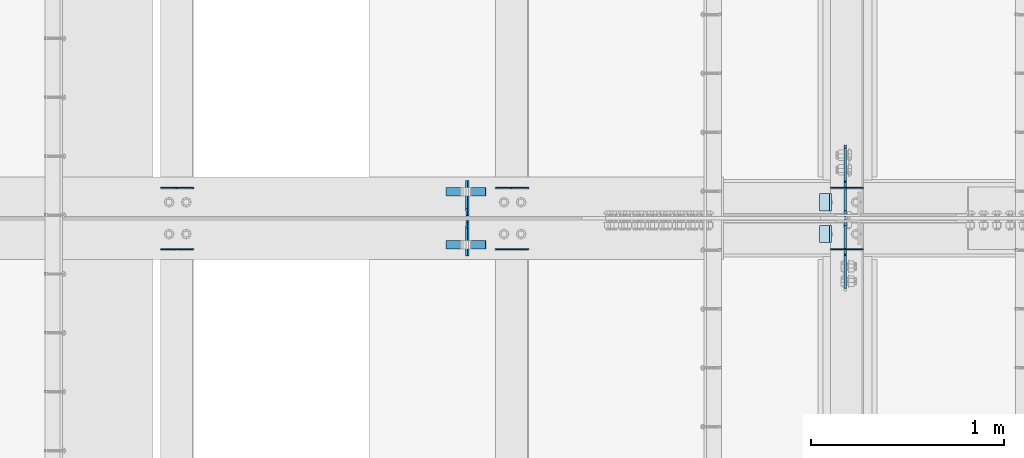
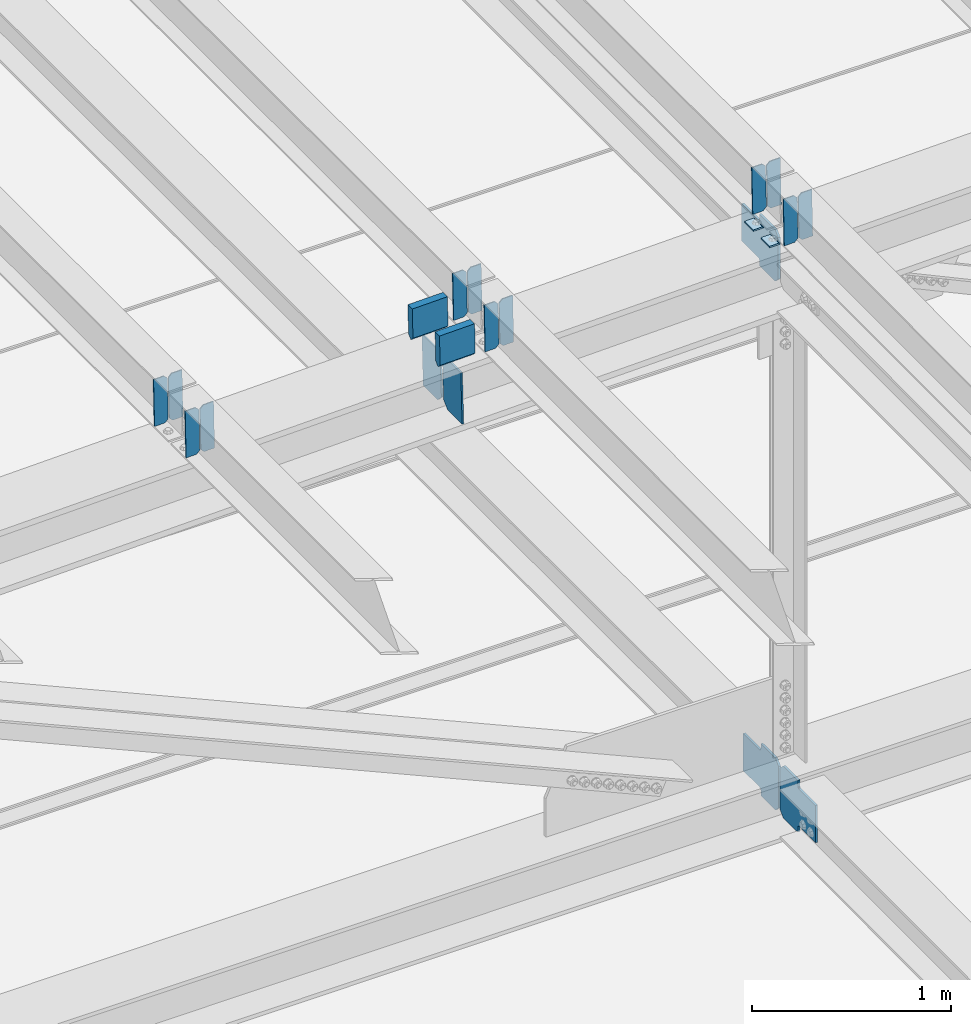
# One storey, part 3292 of 3843: 21 plates, 8 elements without a shape of their own.
"""IFC2X3 building model written with IfcOpenShell, lengths in millimetres."""

from ifc_helpers import new_model, si_unit, frame, origin_with_axes, place, context, subcontext, project, spatial, faceted_brep, material, type_object, element, aggregate, save


model = new_model("IFC2X3")

# Units and contexts
model_context = context("Model", 3, precision=1e-05, world=origin_with_axes())
body_context = subcontext(model_context, "Body", "Model", "MODEL_VIEW")
ifc_project = project(units=[si_unit("LENGTHUNIT", "METRE", prefix="MILLI"), si_unit("AREAUNIT", "SQUARE_METRE"), si_unit("VOLUMEUNIT", "CUBIC_METRE"), si_unit("MASSUNIT", "GRAM", prefix="KILO"), si_unit("TIMEUNIT", "SECOND"), si_unit("PLANEANGLEUNIT", "RADIAN"), si_unit("SOLIDANGLEUNIT", "STERADIAN"), si_unit("THERMODYNAMICTEMPERATUREUNIT", "DEGREE_CELSIUS"), si_unit("LUMINOUSINTENSITYUNIT", "LUMEN")], contexts=[model_context])

# Site, building, storey
site_placement = place(None, origin_with_axes())
site = spatial("IfcSite", under=ifc_project, at=site_placement, CompositionType="ELEMENT")
building_placement = place(site_placement, origin_with_axes())
building = spatial("IfcBuilding", under=site, at=building_placement, Name="Undefined", CompositionType="ELEMENT")
storey_placement = place(building_placement, origin_with_axes())
storey = spatial("IfcBuildingStorey", under=building, at=storey_placement, Name="Undefined", CompositionType="ELEMENT", Elevation=0.0)

# Assembly, plates
assembly_1_placement = place(storey_placement, origin_with_axes())
assembly_1 = element("IfcElementAssembly", 1, at=assembly_1_placement, inside=storey, Name="BEAM", AssemblyPlace="NOTDEFINED", PredefinedType="RIGID_FRAME")
ifc_material = material(Name="STEEL/A572-50")
plate_type_1 = type_object("IfcPlateType", PredefinedType="NOTDEFINED")
plate_1_placement = place(assembly_1_placement, frame((49078.8964783429, 42358.0054631626, 45746.0795155229), z_axis=(-0.0211520980083369, -0.00110850299980666, 0.999775654820093), x_axis=(-0.999776269348562, 2.42819999967805e-05, -0.0211520840074087)))
plate_1 = element("IfcPlate", 2, at=plate_1_placement, type_object=plate_type_1, material=ifc_material, Name="PLATE", context=body_context, shape_type="Brep", body=[
    faceted_brep([(0.0, -3.17499999999927, 0.0), (6.83940015733242e-10, -3.17499999996653, 288.924999998613), (6.54836185276508e-10, 3.17500000001746, 288.924999998591), (0.0, 3.17499999999927, 0.0), (60.3250007643655, -3.17500000017753, 288.924999998606), (60.3250007643219, 3.17499999979918, 288.924999998584), (79.3750000013097, -3.17500000025029, 269.875000761494), (79.375000001266, 3.17499999972642, 269.875000761487), (79.375000000713, -3.17500000026484, 19.0499992370605), (79.3750000006985, 3.17499999971187, 19.0499992370533), (60.325000763667, -3.17500000020664, -1.45519152283669e-11), (60.3250007636234, 3.17499999977736, -3.63797880709171e-11)], [[[0, 1, 2, 3]], [[1, 4, 5, 2]], [[4, 6, 7, 5]], [[6, 8, 9, 7]], [[8, 10, 11, 9]], [[10, 0, 3, 11]], [[5, 7, 9, 11, 3, 2]], [[10, 8, 6, 4, 1, 0]]]),
])
plate_2_placement = place(assembly_1_placement, frame((48993.1906576532, 42358.0074736207, 45744.266253037), z_axis=(-0.0211520980083369, -0.00110850299980666, 0.999775654820093), x_axis=(-0.999776269348562, 2.42819999967805e-05, -0.0211520840074087)))
plate_2 = element("IfcPlate", 3, at=plate_2_placement, type_object=plate_type_1, material=ifc_material, Name="PLATE", context=body_context, shape_type="Brep", body=[
    faceted_brep([(4.36557456851006e-11, -3.17499999998836, 19.0499992370969), (6.11180439591408e-10, -3.17499999996653, 269.875000761516), (5.96628524363041e-10, 3.17500000001746, 269.875000761502), (1.45519152283669e-11, 3.17499999998836, 19.0499992370824), (19.0499992376572, -3.17500000003201, 288.924999998606), (19.0499992376281, 3.1749999999447, 288.924999998584), (79.3750000013242, -3.17500000025029, 288.924999998591), (79.3750000013097, 3.1749999997337, 288.92499999857), (79.3750000006548, -3.17500000026484, -2.18278728425503e-11), (79.3750000006403, 3.17499999969732, -2.91038304567337e-11), (19.0499992370023, -3.17500000005384, 0.0), (19.0499992369587, 3.17499999992287, -1.45519152283669e-11)], [[[0, 1, 2, 3]], [[1, 4, 5, 2]], [[4, 6, 7, 5]], [[6, 8, 9, 7]], [[8, 10, 11, 9]], [[10, 0, 3, 11]], [[5, 7, 9, 11, 3, 2]], [[10, 8, 6, 4, 1, 0]]]),
])

assembly_2_placement = place(storey_placement, origin_with_axes())
assembly_2 = element("IfcElementAssembly", 4, at=assembly_2_placement, inside=storey, Name="BEAM", AssemblyPlace="NOTDEFINED", PredefinedType="RIGID_FRAME")
plate_3_placement = place(assembly_2_placement, frame((49078.8964783465, 42041.8179140765, 45745.0264253251), z_axis=(-0.0211520981022549, -0.00549162299942689, 0.999761186895503), x_axis=(-0.999776269345233, 0.000116185000071389, -0.0211517790072879)))
plate_3 = element("IfcPlate", 5, at=plate_3_placement, type_object=plate_type_1, material=ifc_material, Name="PLATE", context=body_context, shape_type="Brep", body=[
    faceted_brep([(0.0, -3.17499999999927, 0.0), (6.83940015733242e-10, -3.17499999996653, 288.924999998613), (6.54836185276508e-10, 3.17500000001746, 288.924999998591), (0.0, 3.17499999999927, 0.0), (60.3250007643655, -3.17500000017753, 288.924999998606), (60.3250007643219, 3.17499999979918, 288.924999998584), (79.3750000013097, -3.17500000025029, 269.875000761494), (79.375000001266, 3.17499999972642, 269.875000761487), (79.375000000713, -3.17500000026484, 19.0499992370605), (79.3750000006985, 3.17499999971187, 19.0499992370533), (60.325000763667, -3.17500000020664, -1.45519152283669e-11), (60.3250007636234, 3.17499999977736, -3.63797880709171e-11)], [[[0, 1, 2, 3]], [[1, 4, 5, 2]], [[4, 6, 7, 5]], [[6, 8, 9, 7]], [[8, 10, 11, 9]], [[10, 0, 3, 11]], [[5, 7, 9, 11, 3, 2]], [[10, 8, 6, 4, 1, 0]]]),
])
plate_4_placement = place(assembly_2_placement, frame((48993.1906576568, 42041.8278740651, 45743.2131890787), z_axis=(-0.0211520981022549, -0.00549162299942689, 0.999761186895503), x_axis=(-0.999776269345233, 0.000116185000071389, -0.0211517790072879)))
plate_4 = element("IfcPlate", 6, at=plate_4_placement, type_object=plate_type_1, material=ifc_material, Name="PLATE", context=body_context, shape_type="Brep", body=[
    faceted_brep([(4.36557456851006e-11, -3.17499999998836, 19.0499992370969), (6.11180439591408e-10, -3.17499999996653, 269.875000761516), (5.96628524363041e-10, 3.17500000001746, 269.875000761502), (1.45519152283669e-11, 3.17499999998836, 19.0499992370824), (19.0499992376572, -3.17500000003201, 288.924999998606), (19.0499992376281, 3.1749999999447, 288.924999998584), (79.3750000013242, -3.17500000025029, 288.924999998591), (79.3750000013097, 3.1749999997337, 288.92499999857), (79.3750000006548, -3.17500000026484, -2.18278728425503e-11), (79.3750000006403, 3.17499999969732, -2.91038304567337e-11), (19.0499992370023, -3.17500000005384, 0.0), (19.0499992369587, 3.17499999992287, -1.45519152283669e-11)], [[[0, 1, 2, 3]], [[1, 4, 5, 2]], [[4, 6, 7, 5]], [[6, 8, 9, 7]], [[8, 10, 11, 9]], [[10, 0, 3, 11]], [[5, 7, 9, 11, 3, 2]], [[10, 8, 6, 4, 1, 0]]]),
])

assembly_3_placement = place(storey_placement, origin_with_axes())
assembly_3 = element("IfcElementAssembly", 7, at=assembly_3_placement, inside=storey, Name="BEAM", AssemblyPlace="NOTDEFINED", PredefinedType="RIGID_FRAME")
plate_5_placement = place(assembly_3_placement, frame((47345.3464782865, 42357.9664026271, 45703.7227700204), z_axis=(-0.0211520981155117, -0.00097741099957784, 0.999775791571815), x_axis=(-0.999776269351802, 2.0345000001943e-05, -0.0211520880074333)))
plate_5 = element("IfcPlate", 8, at=plate_5_placement, type_object=plate_type_1, material=ifc_material, Name="PLATE", context=body_context, shape_type="Brep", body=[
    faceted_brep([(0.0, -3.17499999999927, 0.0), (6.83940015733242e-10, -3.17499999996653, 288.924999998613), (6.54836185276508e-10, 3.17500000001746, 288.924999998591), (0.0, 3.17499999999927, 0.0), (60.3250007643655, -3.17500000017753, 288.924999998606), (60.3250007643219, 3.17499999979918, 288.924999998584), (79.3750000013097, -3.17500000025029, 269.875000761494), (79.375000001266, 3.17499999972642, 269.875000761487), (79.375000000713, -3.17500000026484, 19.0499992370605), (79.3750000006985, 3.17499999971187, 19.0499992370533), (60.325000763667, -3.17500000020664, -1.45519152283669e-11), (60.3250007636234, 3.17499999977736, -3.63797880709171e-11)], [[[0, 1, 2, 3]], [[1, 4, 5, 2]], [[4, 6, 7, 5]], [[6, 8, 9, 7]], [[8, 10, 11, 9]], [[10, 0, 3, 11]], [[5, 7, 9, 11, 3, 2]], [[10, 8, 6, 4, 1, 0]]]),
])
plate_6_placement = place(assembly_3_placement, frame((47259.6406575968, 42357.9681753262, 45701.9095072867), z_axis=(-0.0211520981155117, -0.00097741099957784, 0.999775791571815), x_axis=(-0.999776269351802, 2.0345000001943e-05, -0.0211520880074333)))
plate_6 = element("IfcPlate", 9, at=plate_6_placement, type_object=plate_type_1, material=ifc_material, Name="PLATE", context=body_context, shape_type="Brep", body=[
    faceted_brep([(4.36557456851006e-11, -3.17499999998836, 19.0499992370969), (6.11180439591408e-10, -3.17499999996653, 269.875000761516), (5.96628524363041e-10, 3.17500000001746, 269.875000761502), (1.45519152283669e-11, 3.17499999998836, 19.0499992370824), (19.0499992376572, -3.17500000003201, 288.924999998606), (19.0499992376281, 3.1749999999447, 288.924999998584), (79.3750000013242, -3.17500000025029, 288.924999998591), (79.3750000013097, 3.1749999997337, 288.92499999857), (79.3750000006548, -3.17500000026484, -2.18278728425503e-11), (79.3750000006403, 3.17499999969732, -2.91038304567337e-11), (19.0499992370023, -3.17500000005384, 0.0), (19.0499992369587, 3.17499999992287, -1.45519152283669e-11)], [[[0, 1, 2, 3]], [[1, 4, 5, 2]], [[4, 6, 7, 5]], [[6, 8, 9, 7]], [[8, 10, 11, 9]], [[10, 0, 3, 11]], [[5, 7, 9, 11, 3, 2]], [[10, 8, 6, 4, 1, 0]]]),
])
aggregate(assembly_3, [plate_5, plate_6])

assembly_4_placement = place(storey_placement, origin_with_axes())
assembly_4 = element("IfcElementAssembly", 10, at=assembly_4_placement, inside=storey, Name="BEAM", AssemblyPlace="NOTDEFINED", PredefinedType="RIGID_FRAME")
plate_7_placement = place(assembly_4_placement, frame((47345.3464782612, 42041.6448297769, 45702.7817833533), z_axis=(-0.0211520975680761, -0.00491457500028629, 0.999764190057354), x_axis=(-0.999776269348186, 0.0001032410000617, -0.0211518460073737)))
plate_7 = element("IfcPlate", 11, at=plate_7_placement, type_object=plate_type_1, material=ifc_material, Name="PLATE", context=body_context, shape_type="Brep", body=[
    faceted_brep([(0.0, -3.17499999999927, 0.0), (6.83940015733242e-10, -3.17499999996653, 288.924999998613), (6.54836185276508e-10, 3.17500000001746, 288.924999998591), (0.0, 3.17499999999927, 0.0), (60.3250007643655, -3.17500000017753, 288.924999998606), (60.3250007643219, 3.17499999979918, 288.924999998584), (79.3750000013097, -3.17500000025029, 269.875000761494), (79.375000001266, 3.17499999972642, 269.875000761487), (79.375000000713, -3.17500000026484, 19.0499992370605), (79.3750000006985, 3.17499999971187, 19.0499992370533), (60.325000763667, -3.17500000020664, -1.45519152283669e-11), (60.3250007636234, 3.17499999977736, -3.63797880709171e-11)], [[[0, 1, 2, 3]], [[1, 4, 5, 2]], [[4, 6, 7, 5]], [[6, 8, 9, 7]], [[8, 10, 11, 9]], [[10, 0, 3, 11]], [[5, 7, 9, 11, 3, 2]], [[10, 8, 6, 4, 1, 0]]]),
])
plate_8_placement = place(assembly_4_placement, frame((47259.6406575719, 42041.6537431912, 45700.9685416603), z_axis=(-0.0211520975680761, -0.00491457500028629, 0.999764190057354), x_axis=(-0.999776269348186, 0.0001032410000617, -0.0211518460073737)))
plate_8 = element("IfcPlate", 12, at=plate_8_placement, type_object=plate_type_1, material=ifc_material, Name="PLATE", context=body_context, shape_type="Brep", body=[
    faceted_brep([(4.36557456851006e-11, -3.17499999998836, 19.0499992370969), (6.11180439591408e-10, -3.17499999996653, 269.875000761516), (5.96628524363041e-10, 3.17500000001746, 269.875000761502), (1.45519152283669e-11, 3.17499999998836, 19.0499992370824), (19.0499992376572, -3.17500000003201, 288.924999998606), (19.0499992376281, 3.1749999999447, 288.924999998584), (79.3750000013242, -3.17500000025029, 288.924999998591), (79.3750000013097, 3.1749999997337, 288.92499999857), (79.3750000006548, -3.17500000026484, -2.18278728425503e-11), (79.3750000006403, 3.17499999969732, -2.91038304567337e-11), (19.0499992370023, -3.17500000005384, 0.0), (19.0499992369587, 3.17499999992287, -1.45519152283669e-11)], [[[0, 1, 2, 3]], [[1, 4, 5, 2]], [[4, 6, 7, 5]], [[6, 8, 9, 7]], [[8, 10, 11, 9]], [[10, 0, 3, 11]], [[5, 7, 9, 11, 3, 2]], [[10, 8, 6, 4, 1, 0]]]),
])
aggregate(assembly_4, [plate_7, plate_8])

assembly_5_placement = place(storey_placement, origin_with_axes())
assembly_5 = element("IfcElementAssembly", 13, at=assembly_5_placement, inside=storey, Name="BEAM", AssemblyPlace="NOTDEFINED", PredefinedType="RIGID_FRAME")
plate_9_placement = place(assembly_5_placement, frame((45611.7964782869, 42357.9250457526, 45660.851096023), z_axis=(-0.0211520984488161, -0.000838631999671634, 0.999775917607331), x_axis=(-0.999776269348206, 1.83440000095906e-05, -0.0211520900074109)))
plate_9 = element("IfcPlate", 14, at=plate_9_placement, type_object=plate_type_1, material=ifc_material, Name="PLATE", context=body_context, shape_type="Brep", body=[
    faceted_brep([(0.0, -3.17499999999927, 0.0), (6.83940015733242e-10, -3.17499999996653, 288.924999998613), (6.54836185276508e-10, 3.17500000001746, 288.924999998591), (0.0, 3.17499999999927, 0.0), (60.3250007643655, -3.17500000017753, 288.924999998606), (60.3250007643219, 3.17499999979918, 288.924999998584), (79.3750000013097, -3.17500000025029, 269.875000761494), (79.375000001266, 3.17499999972642, 269.875000761487), (79.375000000713, -3.17500000026484, 19.0499992370605), (79.3750000006985, 3.17499999971187, 19.0499992370533), (60.325000763667, -3.17500000020664, -1.45519152283669e-11), (60.3250007636234, 3.17499999977736, -3.63797880709171e-11)], [[[0, 1, 2, 3]], [[1, 4, 5, 2]], [[4, 6, 7, 5]], [[6, 8, 9, 7]], [[8, 10, 11, 9]], [[10, 0, 3, 11]], [[5, 7, 9, 11, 3, 2]], [[10, 8, 6, 4, 1, 0]]]),
])
plate_10_placement = place(assembly_5_placement, frame((45526.0906575972, 42357.9265667542, 45659.0378330607), z_axis=(-0.0211520984488161, -0.000838631999671634, 0.999775917607331), x_axis=(-0.999776269348206, 1.83440000095906e-05, -0.0211520900074109)))
plate_10 = element("IfcPlate", 15, at=plate_10_placement, type_object=plate_type_1, material=ifc_material, Name="PLATE", context=body_context, shape_type="Brep", body=[
    faceted_brep([(4.36557456851006e-11, -3.17499999998836, 19.0499992370969), (6.11180439591408e-10, -3.17499999996653, 269.875000761516), (5.96628524363041e-10, 3.17500000001746, 269.875000761502), (1.45519152283669e-11, 3.17499999998836, 19.0499992370824), (19.0499992376572, -3.17500000003201, 288.924999998606), (19.0499992376281, 3.1749999999447, 288.924999998584), (79.3750000013242, -3.17500000025029, 288.924999998591), (79.3750000013097, 3.1749999997337, 288.92499999857), (79.3750000006548, -3.17500000026484, -2.18278728425503e-11), (79.3750000006403, 3.17499999969732, -2.91038304567337e-11), (19.0499992370023, -3.17500000005384, 0.0), (19.0499992369587, 3.17499999992287, -1.45519152283669e-11)], [[[0, 1, 2, 3]], [[1, 4, 5, 2]], [[4, 6, 7, 5]], [[6, 8, 9, 7]], [[8, 10, 11, 9]], [[10, 0, 3, 11]], [[5, 7, 9, 11, 3, 2]], [[10, 8, 6, 4, 1, 0]]]),
])
aggregate(assembly_5, [plate_9, plate_10])

assembly_6_placement = place(storey_placement, origin_with_axes())
assembly_6 = element("IfcElementAssembly", 16, at=assembly_6_placement, inside=storey, Name="BEAM", AssemblyPlace="NOTDEFINED", PredefinedType="RIGID_FRAME")
plate_11_placement = place(assembly_6_placement, frame((45611.7964782758, 42041.4534319439, 45660.0334016833), z_axis=(-0.0211520984749004, -0.00427606199955335, 0.999767124896535), x_axis=(-0.999776269337349, 9.04680000567301e-05, -0.0211519050071807)))
plate_11 = element("IfcPlate", 17, at=plate_11_placement, type_object=plate_type_1, material=ifc_material, Name="PLATE", context=body_context, shape_type="Brep", body=[
    faceted_brep([(0.0, -3.17499999999927, 0.0), (6.83940015733242e-10, -3.17499999996653, 288.924999998613), (6.54836185276508e-10, 3.17500000001746, 288.924999998591), (0.0, 3.17499999999927, 0.0), (60.3250007643655, -3.17500000017753, 288.924999998606), (60.3250007643219, 3.17499999979918, 288.924999998584), (79.3750000013097, -3.17500000025029, 269.875000761494), (79.375000001266, 3.17499999972642, 269.875000761487), (79.375000000713, -3.17500000026484, 19.0499992370605), (79.3750000006985, 3.17499999971187, 19.0499992370533), (60.325000763667, -3.17500000020664, -1.45519152283669e-11), (60.3250007636234, 3.17499999977736, -3.63797880709171e-11)], [[[0, 1, 2, 3]], [[1, 4, 5, 2]], [[4, 6, 7, 5]], [[6, 8, 9, 7]], [[8, 10, 11, 9]], [[10, 0, 3, 11]], [[5, 7, 9, 11, 3, 2]], [[10, 8, 6, 4, 1, 0]]]),
])
plate_12_placement = place(assembly_6_placement, frame((45526.0906575865, 42041.4611873052, 45658.2201546672), z_axis=(-0.0211520984749004, -0.00427606199955335, 0.999767124896535), x_axis=(-0.999776269337349, 9.04680000567301e-05, -0.0211519050071807)))
plate_12 = element("IfcPlate", 18, at=plate_12_placement, type_object=plate_type_1, material=ifc_material, Name="PLATE", context=body_context, shape_type="Brep", body=[
    faceted_brep([(4.36557456851006e-11, -3.17499999998836, 19.0499992370969), (6.11180439591408e-10, -3.17499999996653, 269.875000761516), (5.96628524363041e-10, 3.17500000001746, 269.875000761502), (1.45519152283669e-11, 3.17499999998836, 19.0499992370824), (19.0499992376572, -3.17500000003201, 288.924999998606), (19.0499992376281, 3.1749999999447, 288.924999998584), (79.3750000013242, -3.17500000025029, 288.924999998591), (79.3750000013097, 3.1749999997337, 288.92499999857), (79.3750000006548, -3.17500000026484, -2.18278728425503e-11), (79.3750000006403, 3.17499999969732, -2.91038304567337e-11), (19.0499992370023, -3.17500000005384, 0.0), (19.0499992369587, 3.17499999992287, -1.45519152283669e-11)], [[[0, 1, 2, 3]], [[1, 4, 5, 2]], [[4, 6, 7, 5]], [[6, 8, 9, 7]], [[8, 10, 11, 9]], [[10, 0, 3, 11]], [[5, 7, 9, 11, 3, 2]], [[10, 8, 6, 4, 1, 0]]]),
])
aggregate(assembly_6, [plate_11, plate_12])

assembly_7_placement = place(storey_placement, origin_with_axes())
assembly_7 = element("IfcElementAssembly", 19, at=assembly_7_placement, inside=storey, Name="BEAM", AssemblyPlace="NOTDEFINED", PredefinedType="RIGID_FRAME")
plate_type_2 = type_object("IfcPlateType", PredefinedType="NOTDEFINED")
plate_13_placement = place(assembly_7_placement, frame((47032.7603488279, 42006.5375, 45329.6571292325), z_axis=(-0.0251104770065213, 0.0, 0.999684682259614), x_axis=(0.0, 1.0, 0.0)))
plate_13 = element("IfcPlate", 20, at=plate_13_placement, type_object=plate_type_2, material=ifc_material, Name="PL", context=body_context, shape_type="Brep", body=[
    faceted_brep([(0.0, -4.76249999999709, 0.0), (0.0, -4.76249999986612, 316.896679377329), (0.0, 4.7625000001135, 316.896679377329), (0.0, 4.76249999999709, 0.0), (145.748320007318, -4.76249999986612, 316.896679377329), (145.748320007318, 4.7625000001135, 316.896679377329), (184.149999999994, -4.76249999988067, 278.494999384784), (184.149999999994, 4.76250000009895, 278.494999384777), (184.149999999994, -4.76249999998254, 38.4016799925521), (184.149999999994, 4.76249999999709, 38.4016799925594), (145.748320007318, -4.76249999999709, 7.27595761418343e-12), (145.748320007318, 4.76249999996799, 0.0)], [[[0, 1, 2, 3]], [[1, 4, 5, 2]], [[4, 6, 7, 5]], [[6, 8, 9, 7]], [[8, 10, 11, 9]], [[10, 0, 3, 11]], [[5, 7, 9, 11, 3, 2]], [[10, 8, 6, 4, 1, 0]]]),
])
plate_14_placement = place(assembly_7_placement, frame((47032.7603488279, 42213.5125, 45329.6571292325), z_axis=(-0.0251104770065213, 0.0, 0.999684682259614), x_axis=(0.0, 1.0, 0.0)))
plate_14 = element("IfcPlate", 21, at=plate_14_placement, type_object=plate_type_2, material=ifc_material, Name="PL", context=body_context, shape_type="Brep", body=[
    faceted_brep([(0.0, -4.76249999998254, 38.4016799925521), (0.0, -4.76249999988067, 278.494999384784), (0.0, 4.76250000009895, 278.494999384777), (0.0, 4.76249999999709, 38.4016799925594), (38.4016799926758, -4.76249999986612, 316.896679377329), (38.4016799926758, 4.7625000001135, 316.896679377329), (184.149999999994, -4.76249999986612, 316.896679377329), (184.149999999994, 4.7625000001135, 316.896679377329), (184.150000000009, -4.76249999999709, 0.0), (184.150000000009, 4.76249999999709, 0.0), (38.4016799926758, -4.76249999999709, 7.27595761418343e-12), (38.4016799926758, 4.76249999996799, 0.0)], [[[0, 1, 2, 3]], [[1, 4, 5, 2]], [[4, 6, 7, 5]], [[6, 8, 9, 7]], [[8, 10, 11, 9]], [[10, 0, 3, 11]], [[5, 7, 9, 11, 3, 2]], [[10, 8, 6, 4, 1, 0]]]),
])
plate_type_3 = type_object("IfcPlateType", PredefinedType="NOTDEFINED")
plate_15_placement = place(assembly_7_placement, frame((46917.7963650314, 42338.228125, 45885.6915529663), z_axis=(0.0217666070074993, 0.0, -0.999763079343992), x_axis=(0.999763079343992, 0.0, 0.0217666070075027)))
plate_15 = element("IfcPlate", 22, at=plate_15_placement, type_object=plate_type_3, material=ifc_material, Name="PLATE", context=body_context, shape_type="Brep", body=[
    faceted_brep([(203.200005058941, -22.2250000000058, -1.16415321826935e-10), (7.27595761418343e-12, -22.2250000000058, -7.27595761418343e-12), (7.27595761418343e-12, 22.2250000000058, -7.27595761418343e-12), (203.200005058941, 22.2250000000058, -1.16415321826935e-10), (203.838531807472, -22.2250000000058, 0.00187068080413155), (203.838531807472, 22.2250000000058, 0.00187068080413155), (203.310341304641, -22.2250000000058, 180.861817383484), (0.04046799018397, -22.2250000000058, 180.907287948779), (203.245434494536, 0.0133131837355904, 203.086833080139), (0.0454396034692763, 0.0133129994646879, 203.132287829787), (0.0404679902494536, 22.2250000000058, 180.907288225317), (203.310341303353, 22.2250000000058, 180.861817822159)], [[[0, 1, 2, 3]], [[4, 0, 3, 5]], [[1, 0, 4, 6, 7]], [[7, 6, 8, 9]], [[2, 1, 7, 9, 10]], [[5, 3, 2, 10, 11]], [[6, 4, 5, 11, 8]], [[10, 9, 8, 11]]]),
])
plate_16_placement = place(assembly_7_placement, frame((46917.7963650314, 42065.178125, 45885.6915529663), z_axis=(0.0217666070074993, 0.0, -0.999763079343992), x_axis=(0.999763079343992, 0.0, 0.0217666070075027)))
plate_16 = element("IfcPlate", 23, at=plate_16_placement, type_object=plate_type_3, material=ifc_material, Name="PLATE", context=body_context, shape_type="Brep", body=[
    faceted_brep([(203.200005058941, -22.2250000000058, -1.16415321826935e-10), (7.27595761418343e-12, -22.2250000000058, -7.27595761418343e-12), (7.27595761418343e-12, 22.2250000000058, -7.27595761418343e-12), (203.200005058941, 22.2250000000058, -1.16415321826935e-10), (203.838531807472, -22.2250000000058, 0.00187068080413155), (203.838531807472, 22.2250000000058, 0.00187068080413155), (203.310341304641, -22.2250000000058, 180.861817383484), (0.04046799018397, -22.2250000000058, 180.907287948779), (203.245434494536, 0.0133131837355904, 203.086833080139), (0.0454396034692763, 0.0133129994646879, 203.132287829787), (0.0404679902494536, 22.2250000000058, 180.907288225317), (203.310341303353, 22.2250000000058, 180.861817822159)], [[[0, 1, 2, 3]], [[4, 0, 3, 5]], [[1, 0, 4, 6, 7]], [[7, 6, 8, 9]], [[2, 1, 7, 9, 10]], [[5, 3, 2, 10, 11]], [[6, 4, 5, 11, 8]], [[10, 9, 8, 11]]]),
])

# Plate
plate_type_4 = type_object("IfcPlateType", PredefinedType="NOTDEFINED")
plate_17_placement = place(assembly_1_placement, frame((48913.9677301051, 42329.1, 45736.0659531248), z_axis=(0.0, -1.0, 0.0), x_axis=(-0.999776270257024, 0.0, -0.0211520550054595)))
plate_17 = element("IfcPlate", 24, at=plate_17_placement, type_object=plate_type_4, material=ifc_material, Name="PLATE", context=body_context, shape_type="Brep", body=[
    faceted_brep([(9.52499999982683, -4.7625000001135, 88.8999999999942), (0.0, 4.76249999999709, 88.9000015258789), (0.0, 4.76249999999709, 0.0), (9.52499999981956, -4.76249999999709, 0.0), (63.4999984608512, -4.76249999988795, 88.8999999999796), (63.4999984608367, -4.76249999988795, -1.45519152283669e-11), (63.4999984608221, 4.76250000013533, -1.45519152283669e-11), (63.4999984608367, 4.76250000013533, 88.8999999999796)], [[[0, 1, 2, 3]], [[4, 5, 6, 7]], [[5, 4, 0, 3]], [[6, 5, 3, 2]], [[7, 6, 2, 1]], [[4, 7, 1, 0]]]),
])

aggregate(assembly_1, [plate_1, plate_2, plate_17])

plate_18_placement = place(assembly_2_placement, frame((48913.9677301051, 42164.0000015258, 45736.0659531248), z_axis=(0.0, -1.0, 0.0), x_axis=(-0.999776270257024, 0.0, -0.0211520550054595)))
plate_18 = element("IfcPlate", 25, at=plate_18_placement, type_object=plate_type_4, material=ifc_material, Name="PLATE", context=body_context, shape_type="Brep", body=[
    faceted_brep([(9.52499999982683, -4.7625000001135, 88.8999999999942), (0.0, 4.76249999999709, 88.9000015258789), (0.0, 4.76249999999709, 0.0), (9.52499999981956, -4.76249999999709, 0.0), (63.4999984608512, -4.76249999988795, 88.8999999999796), (63.4999984608367, -4.76249999988795, -1.45519152283669e-11), (63.4999984608221, 4.76250000013533, -1.45519152283669e-11), (63.4999984608367, 4.76250000013533, 88.8999999999796)], [[[0, 1, 2, 3]], [[4, 5, 6, 7]], [[5, 4, 0, 3]], [[6, 5, 3, 2]], [[7, 6, 2, 1]], [[4, 7, 1, 0]]]),
])

aggregate(assembly_2, [plate_3, plate_4, plate_18])

# Assembly, plates
assembly_8_placement = place(storey_placement, origin_with_axes())
assembly_8 = element("IfcElementAssembly", 26, at=assembly_8_placement, inside=storey, Name="BEAM", AssemblyPlace="NOTDEFINED", PredefinedType="RIGID_FRAME")
plate_type_5 = type_object("IfcPlateType", PredefinedType="NOTDEFINED")
plate_19_placement = place(assembly_8_placement, frame((48985.4874999047, 42209.24375, 42171.4406335446), z_axis=(0.0, 0.707106781186548, 0.707106781186548), x_axis=(5.70000238222118e-08, 0.707106781186546, -0.707106781186546)))
plate_19 = element("IfcPlate", 27, at=plate_19_placement, type_object=plate_type_5, material=ifc_material, Name="PLATE", context=body_context, shape_type="Brep", body=[
    faceted_brep([(0.0, -6.3499999046162, 0.0), (-179.578190893319, -6.34999999999854, 179.578190893313), (-179.578190893319, 6.34999999999854, 179.578190893313), (7.27595761418343e-12, 6.3499999046162, 0.0), (-179.578190893082, -6.34999999999854, 224.479471498686), (-179.578190893082, 6.34999999999854, 224.479471498686), (-75.7439794552577, -6.34999999999854, 328.313682936503), (-75.7439794552577, 6.34999999999854, 328.313682936503), (-53.5220167924802, -6.34999999999854, 306.091720273726), (-53.5220167924802, 6.34999999999854, 306.091720273726), (-49.4018403243375, -6.34999999999854, 303.338706373259), (-49.4018403243375, 6.34999999999854, 303.338706373259), (-44.5417608063056, -6.34999999999854, 302.371976450668), (-44.5417608063056, 6.34999999999854, 302.371976450668), (-39.6816812882701, -6.34999999999854, 303.338706373259), (-39.6816812882701, 6.34999999999854, 303.338706373259), (-35.5615048201238, -6.34999999999854, 306.091720273726), (-35.5615048201238, 6.34999999999854, 306.091720273726), (81.1818248519645, -6.34999999999854, 422.835049945817), (81.1818248519645, 6.34999999999854, 422.835049945817), (242.826435030436, -6.34999999999854, 261.190439767342), (242.826435030436, 6.34999999999854, 261.190439767342), (126.083105358348, -6.34999999999854, 144.447110095258), (126.083105358348, 6.34999999999854, 144.447110095258), (123.330091457874, -6.34999999999854, 140.326933627111), (123.330091457874, 6.34999999999854, 140.326933627111), (122.36336153529, -6.34999999999854, 135.46685410908), (122.36336153529, 6.34999999999854, 135.46685410908), (123.330091457874, -6.34999999999854, 130.606774591048), (123.330091457874, 6.34999999999854, 130.606774591048), (126.083105358348, -6.34999999999854, 126.486598122901), (126.083105358348, 6.34999999999854, 126.486598122901), (148.735492004496, -6.35000000000582, 103.834211399357), (148.735492004496, 6.35000000000582, 103.834211399357), (44.9012806051323, -6.35000000000582, -1.45519152283669e-11), (44.9012806051323, 6.35000000000582, -1.45519152283669e-11)], [[[0, 1, 2, 3]], [[1, 4, 5, 2]], [[4, 6, 7, 5]], [[6, 8, 9, 7]], [[8, 10, 11, 9]], [[10, 12, 13, 11]], [[12, 14, 15, 13]], [[14, 16, 17, 15]], [[16, 18, 19, 17]], [[18, 20, 21, 19]], [[20, 22, 23, 21]], [[22, 24, 25, 23]], [[24, 26, 27, 25]], [[26, 28, 29, 27]], [[28, 30, 31, 29]], [[30, 32, 33, 31]], [[32, 34, 35, 33]], [[34, 0, 3, 35]], [[5, 7, 9, 11, 13, 15, 17, 19, 21, 23, 25, 27, 29, 31, 33, 35, 3, 2]], [[34, 32, 30, 28, 26, 24, 22, 20, 18, 16, 14, 12, 10, 8, 6, 4, 1, 0]]]),
])
plate_20_placement = place(assembly_8_placement, frame((48985.4874998745, 42194.9562499243, 42171.4406337117), z_axis=(0.0, -0.707106781186682, 0.707106781186413), x_axis=(0.0, -0.707106781186548, -0.707106781186548)))
plate_20 = element("IfcPlate", 28, at=plate_20_placement, type_object=plate_type_5, material=ifc_material, Name="PLATE", context=body_context, shape_type="Brep", body=[
    faceted_brep([(0.0, -6.3499999046162, 0.0), (-179.578190893319, -6.34999999999854, 179.578190893313), (-179.578190893319, 6.34999999999854, 179.578190893313), (7.27595761418343e-12, 6.3499999046162, 0.0), (-179.578190893082, -6.34999999999854, 224.479471498686), (-179.578190893082, 6.34999999999854, 224.479471498686), (-75.7439794552577, -6.34999999999854, 328.313682936503), (-75.7439794552577, 6.34999999999854, 328.313682936503), (-52.3885539019466, -6.34999999999854, 304.958257313201), (-52.3885539019466, 6.34999999999854, 304.958257313201), (-48.2683774338147, -6.34999999999854, 302.205243412731), (-48.2683774338147, 6.34999999999854, 302.205243412731), (-43.4082979157902, -6.34999999999854, 301.238513490147), (-43.4082979157902, 6.34999999999854, 301.238513490147), (-38.5482183977656, -6.34999999999854, 302.205243412716), (-38.5482183977656, 6.34999999999854, 302.205243412716), (-34.4280419296338, -6.34999999999854, 304.958257313164), (-34.4280419296338, 6.34999999999854, 304.958257313164), (82.3152877752509, -6.34999999999854, 421.701587017052), (82.3152877752509, 6.34999999999854, 421.701587017052), (243.959897954686, -6.34999999999854, 260.056976837893), (243.959897954686, 6.34999999999854, 260.056976837893), (127.216568249889, -6.34999999999854, 143.3136471341), (127.216568249889, 6.34999999999854, 143.3136471341), (124.463554349401, -6.34999999999854, 139.193470665946), (124.463554349401, 6.34999999999854, 139.193470665946), (123.496824426802, -6.34999999999854, 134.333391147904), (123.496824426802, 6.34999999999854, 134.333391147904), (124.463554349386, -6.34999999999854, 129.473311629857), (124.463554349386, 6.34999999999854, 129.473311629857), (127.216568249867, -6.34999999999854, 125.353135161696), (127.216568249867, 6.34999999999854, 125.353135161696), (148.735492004496, -6.35000000000582, 103.834211399357), (148.735492004496, 6.35000000000582, 103.834211399357), (44.9012806051323, -6.35000000000582, -1.45519152283669e-11), (44.9012806051323, 6.35000000000582, -1.45519152283669e-11)], [[[0, 1, 2, 3]], [[1, 4, 5, 2]], [[4, 6, 7, 5]], [[6, 8, 9, 7]], [[8, 10, 11, 9]], [[10, 12, 13, 11]], [[12, 14, 15, 13]], [[14, 16, 17, 15]], [[16, 18, 19, 17]], [[18, 20, 21, 19]], [[20, 22, 23, 21]], [[22, 24, 25, 23]], [[24, 26, 27, 25]], [[26, 28, 29, 27]], [[28, 30, 31, 29]], [[30, 32, 33, 31]], [[32, 34, 35, 33]], [[34, 0, 3, 35]], [[5, 7, 9, 11, 13, 15, 17, 19, 21, 23, 25, 27, 29, 31, 33, 35, 3, 2]], [[34, 32, 30, 28, 26, 24, 22, 20, 18, 16, 14, 12, 10, 8, 6, 4, 1, 0]]]),
])
aggregate(assembly_8, [plate_19, plate_20])

# Plate
plate_21_placement = place(assembly_7_placement, frame((48985.4875000102, 42213.2125, 45408.9808583001), z_axis=(0.0, 0.707106781186548, 0.707106781186548), x_axis=(5.70000238222118e-08, 0.707106781186546, -0.707106781186546)))
plate_21 = element("IfcPlate", 29, at=plate_21_placement, type_object=plate_type_5, material=ifc_material, Name="PLATE", context=body_context, shape_type="Brep", body=[
    faceted_brep([(0.0, -6.3499999046162, 0.0), (-179.453566079081, -6.34999999999854, 179.453566079137), (-179.453566079081, 6.34999999999854, 179.453566079137), (7.27595761418343e-12, 6.3499999046162, 0.0), (-179.453566079078, -6.34999999999854, 224.354846684269), (-179.453566079078, 6.34999999999854, 224.354846684269), (-68.3228965813564, -6.34999999999854, 335.485516181965), (-68.3228965813564, 6.34999999999854, 335.485516181965), (-46.3379902689289, -6.34999999999854, 313.500609869523), (-46.3379902689289, 6.34999999999854, 313.500609869523), (-42.2178138007898, -6.34999999999854, 310.747595969056), (-42.2178138007898, 6.34999999999854, 310.747595969056), (-37.3577342827507, -6.34999999999854, 309.780866046473), (-37.3577342827507, 6.34999999999854, 309.780866046473), (-32.4976547647152, -6.34999999999854, 310.747595969056), (-32.4976547647152, 6.34999999999854, 310.747595969056), (-28.3774782965725, -6.34999999999854, 313.500609869523), (-28.3774782965725, 6.34999999999854, 313.500609869523), (88.3658514116119, -6.34999999999854, 430.243939577675), (88.3658514116119, 6.34999999999854, 430.243939577675), (250.010461590058, -6.34999999999854, 268.599329399192), (250.010461590058, 6.34999999999854, 268.599329399192), (133.267131881873, -6.34999999999854, 151.855999691041), (133.267131881873, 6.34999999999854, 151.855999691041), (130.514117981403, -6.34999999999854, 147.735823222894), (130.514117981403, 6.34999999999854, 147.735823222894), (129.547388058819, -6.34999999999854, 142.875743704855), (129.547388058819, 6.34999999999854, 142.875743704855), (130.514117981403, -6.34999999999854, 138.015664186831), (130.514117981403, 6.34999999999854, 138.015664186831), (133.26713188187, -6.34999999999854, 133.895487718684), (133.26713188187, 6.34999999999854, 133.895487718684), (156.031950102829, -6.35000000000582, 111.130669497703), (156.031950102829, 6.35000000000582, 111.130669497703), (44.9012806051323, -6.35000000000582, -1.45519152283669e-11), (44.9012806051323, 6.35000000000582, -1.45519152283669e-11)], [[[0, 1, 2, 3]], [[1, 4, 5, 2]], [[4, 6, 7, 5]], [[6, 8, 9, 7]], [[8, 10, 11, 9]], [[10, 12, 13, 11]], [[12, 14, 15, 13]], [[14, 16, 17, 15]], [[16, 18, 19, 17]], [[18, 20, 21, 19]], [[20, 22, 23, 21]], [[22, 24, 25, 23]], [[24, 26, 27, 25]], [[26, 28, 29, 27]], [[28, 30, 31, 29]], [[30, 32, 33, 31]], [[32, 34, 35, 33]], [[34, 0, 3, 35]], [[5, 7, 9, 11, 13, 15, 17, 19, 21, 23, 25, 27, 29, 31, 33, 35, 3, 2]], [[34, 32, 30, 28, 26, 24, 22, 20, 18, 16, 14, 12, 10, 8, 6, 4, 1, 0]]]),
])

aggregate(assembly_7, [plate_13, plate_14, plate_15, plate_16, plate_21])

save(model, "model.ifc")
